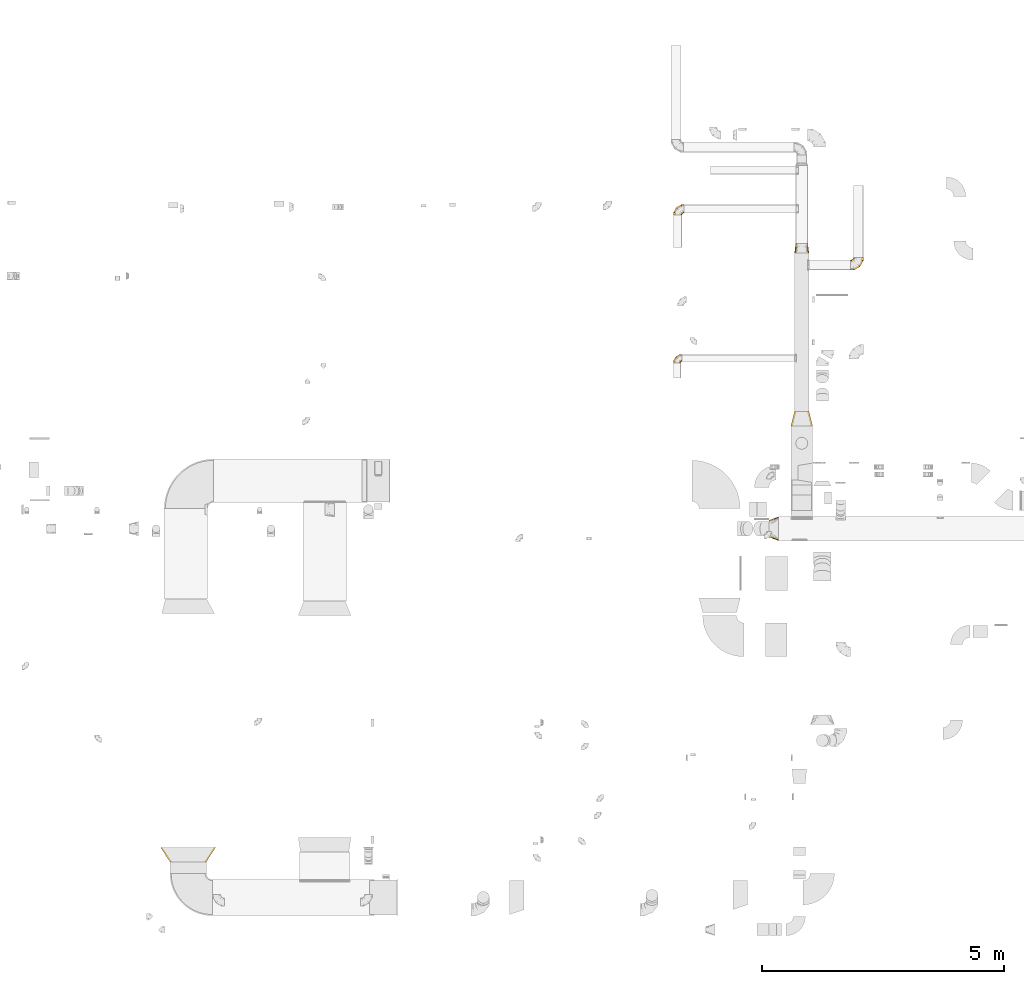
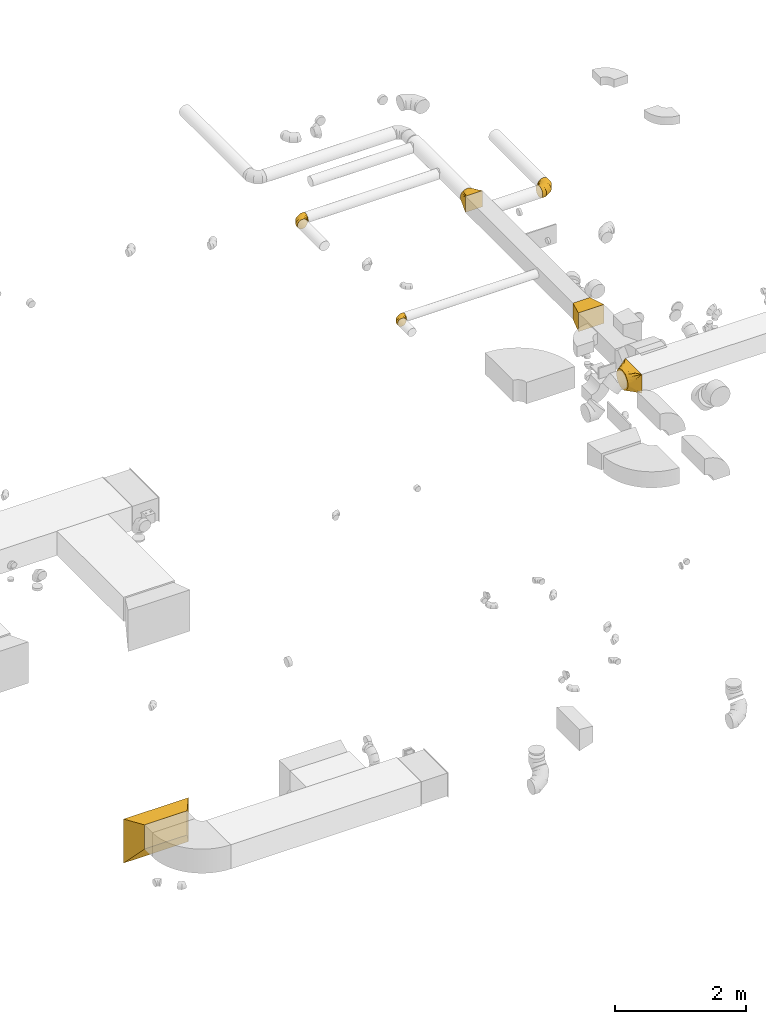
# One storey, part 6 of 62: 7 coverings.
"""IFC2X3 building model written with IfcOpenShell, lengths in millimetres."""

from ifc_helpers import new_model, entity, si_unit, converted_unit, derived_unit, direction, frame, origin, place, context, subcontext, project, spatial, faceted_brep, element, save


model = new_model("IFC2X3")

# Units and contexts
model_context = context("Model", 3, precision=0.01, world=origin(), true_north=direction((6.12303176911189e-17, 1.0)))
body_context = subcontext(model_context, "Body", "Model", "MODEL_VIEW")
ifc_project = project(units=[si_unit("LENGTHUNIT", "METRE", prefix="MILLI"), si_unit("AREAUNIT", "SQUARE_METRE"), si_unit("VOLUMEUNIT", "CUBIC_METRE"), converted_unit("PLANEANGLEUNIT", "DEGREE", entity("IfcRatioMeasure", 0.0174532925199433), si_unit("PLANEANGLEUNIT", "RADIAN"), dimensions=[0, 0, 0, 0, 0, 0, 0]), si_unit("MASSUNIT", "GRAM", prefix="KILO"), derived_unit("MASSDENSITYUNIT", [(si_unit("MASSUNIT", "GRAM", prefix="KILO"), 1), (si_unit("LENGTHUNIT", "METRE"), -3)]), derived_unit("MOMENTOFINERTIAUNIT", [(si_unit("LENGTHUNIT", "METRE"), 4)]), si_unit("TIMEUNIT", "SECOND"), si_unit("FREQUENCYUNIT", "HERTZ"), si_unit("THERMODYNAMICTEMPERATUREUNIT", "DEGREE_CELSIUS"), derived_unit("THERMALTRANSMITTANCEUNIT", [(si_unit("MASSUNIT", "GRAM", prefix="KILO"), 1), (si_unit("THERMODYNAMICTEMPERATUREUNIT", "KELVIN"), -1), (si_unit("TIMEUNIT", "SECOND"), -3)]), derived_unit("VOLUMETRICFLOWRATEUNIT", [(si_unit("LENGTHUNIT", "METRE"), 3), (si_unit("TIMEUNIT", "SECOND"), -1)]), derived_unit("MASSFLOWRATEUNIT", [(si_unit("MASSUNIT", "GRAM", prefix="KILO"), 1), (si_unit("TIMEUNIT", "SECOND"), -1)]), derived_unit("ROTATIONALFREQUENCYUNIT", [(si_unit("TIMEUNIT", "SECOND"), -1)]), si_unit("ELECTRICCURRENTUNIT", "AMPERE"), si_unit("ELECTRICVOLTAGEUNIT", "VOLT"), si_unit("POWERUNIT", "WATT"), si_unit("FORCEUNIT", "NEWTON", prefix="KILO"), si_unit("ILLUMINANCEUNIT", "LUX"), si_unit("LUMINOUSFLUXUNIT", "LUMEN"), si_unit("LUMINOUSINTENSITYUNIT", "CANDELA"), derived_unit("USERDEFINED", [(si_unit("MASSUNIT", "GRAM", prefix="KILO"), -1), (si_unit("LENGTHUNIT", "METRE"), -2), (si_unit("TIMEUNIT", "SECOND"), 3), (si_unit("LUMINOUSFLUXUNIT", "LUMEN"), 1)]), derived_unit("LINEARVELOCITYUNIT", [(si_unit("LENGTHUNIT", "METRE"), 1), (si_unit("TIMEUNIT", "SECOND"), -1)]), si_unit("PRESSUREUNIT", "PASCAL"), derived_unit("USERDEFINED", [(si_unit("LENGTHUNIT", "METRE"), -2), (si_unit("MASSUNIT", "GRAM", prefix="KILO"), 1), (si_unit("TIMEUNIT", "SECOND"), -2)]), derived_unit("LINEARFORCEUNIT", [(si_unit("MASSUNIT", "GRAM", prefix="KILO"), 1), (si_unit("LENGTHUNIT", "METRE"), 1), (si_unit("TIMEUNIT", "SECOND"), -2), (si_unit("LENGTHUNIT", "METRE"), -1)]), derived_unit("PLANARFORCEUNIT", [(si_unit("MASSUNIT", "GRAM", prefix="KILO"), 1), (si_unit("LENGTHUNIT", "METRE"), 1), (si_unit("TIMEUNIT", "SECOND"), -2), (si_unit("LENGTHUNIT", "METRE"), -2)])], contexts=[model_context])

# Site, building, storey
site_placement = place(None, origin())
site = spatial("IfcSite", under=ifc_project, at=site_placement, CompositionType="ELEMENT")
building_placement = place(site_placement, origin())
building = spatial("IfcBuilding", under=site, at=building_placement, CompositionType="ELEMENT")
storey_placement = place(building_placement, frame((0.0, 0.0, 24000.0)))
storey = spatial("IfcBuildingStorey", under=building, at=storey_placement, CompositionType="ELEMENT", Elevation=24000.0)

# Coverings
covering_1_placement = place(storey_placement, frame((39417.06, 8674.98, 3373.4)))
element("IfcCovering", 1, at=covering_1_placement, inside=storey, PredefinedType="INSULATION", context=body_context, shape_type="Brep", body=[
    faceted_brep([(0.0, 98.45, 264.1), (0.0, 112.35, 282.22), (0.0, 126.26, 300.34), (0.0, 144.38, 314.24), (0.0, 162.5, 328.15), (0.0, 183.6, 336.89), (0.0, 204.71, 345.63), (0.0, 218.97, 347.51), (0.0, 233.22, 349.39), (0.0, 250.0, 351.6), (0.0, 266.78, 349.39), (0.0, 281.03, 347.51), (0.0, 295.29, 345.63), (0.0, 316.4, 336.89), (0.0, 337.5, 328.15), (0.0, 355.62, 314.24), (0.0, 373.74, 300.34), (0.0, 387.65, 282.22), (0.0, 401.55, 264.1), (0.0, 410.3, 242.99), (0.0, 419.04, 221.89), (0.0, 420.91, 207.63), (0.0, 422.79, 193.37), (0.0, 425.0, 176.6), (0.0, 422.79, 159.82), (0.0, 420.91, 145.56), (0.0, 419.04, 131.3), (0.0, 410.3, 110.2), (0.0, 401.55, 89.1), (0.0, 387.65, 70.97), (0.0, 373.74, 52.85), (0.0, 355.62, 38.95), (0.0, 337.5, 25.04), (0.0, 316.4, 16.3), (0.0, 295.29, 7.56), (0.0, 281.03, 5.68), (0.0, 266.78, 3.8), (0.0, 250.0, 1.6), (0.0, 233.22, 3.8), (0.0, 218.97, 5.68), (0.0, 204.71, 7.56), (0.0, 183.6, 16.3), (0.0, 162.5, 25.04), (0.0, 144.38, 38.95), (0.0, 126.26, 52.85), (0.0, 112.35, 70.97), (0.0, 98.45, 89.1), (0.0, 89.7, 110.2), (0.0, 80.96, 131.3), (0.0, 79.09, 145.56), (0.0, 77.21, 159.82), (0.0, 75.0, 176.6), (0.0, 77.21, 193.37), (0.0, 79.09, 207.63), (0.0, 80.96, 221.89), (0.0, 89.7, 242.99), (200.0, 0.0, 351.6), (200.0, 0.0, 1.6), (200.0, 500.0, 1.6), (200.0, 500.0, 351.6), (71.91, 160.11, 1.6), (95.89, 130.14, 1.6), (121.91, 97.61, 1.6), (100.0, 66.99, 23.59), (173.97, 32.54, 1.6), (147.94, 19.52, 47.15), (173.97, 9.76, 24.37), (121.91, 29.28, 69.92), (95.89, 39.04, 92.7), (71.91, 48.03, 113.67), (23.97, 220.04, 1.6), (47.94, 190.07, 1.6), (47.94, 57.02, 134.65), (23.97, 66.01, 155.62), (147.94, 65.07, 1.6), (173.97, 9.76, 328.82), (147.94, 19.52, 306.05), (121.91, 29.28, 283.27), (95.89, 39.04, 260.5), (71.91, 48.03, 239.52), (47.94, 57.02, 218.55), (23.97, 66.01, 197.57), (100.0, 59.5, 322.11), (147.94, 65.07, 351.6), (173.97, 32.54, 351.6), (121.91, 97.61, 351.6), (95.89, 130.14, 351.6), (71.91, 160.11, 351.6), (47.94, 190.07, 351.6), (23.97, 220.04, 351.6), (173.97, 467.46, 351.6), (147.94, 434.93, 351.6), (121.91, 402.39, 351.6), (95.89, 369.86, 351.6), (71.91, 339.89, 351.6), (47.94, 309.93, 351.6), (23.97, 279.96, 351.6), (100.0, 433.01, 329.6), (147.94, 480.48, 306.05), (173.97, 490.24, 328.82), (121.91, 470.72, 283.27), (95.89, 460.96, 260.5), (71.91, 451.97, 239.52), (47.94, 442.98, 218.55), (23.97, 433.99, 197.57), (173.97, 490.24, 24.37), (147.94, 480.48, 47.15), (121.91, 470.72, 69.92), (95.89, 460.96, 92.7), (71.91, 451.97, 113.67), (47.94, 442.98, 134.65), (23.97, 433.99, 155.62), (100.0, 440.5, 31.08), (147.94, 434.93, 1.6), (173.97, 467.46, 1.6), (121.91, 402.39, 1.6), (95.89, 369.86, 1.6), (71.91, 339.89, 1.6), (47.94, 309.93, 1.6), (23.97, 279.96, 1.6)], [[[0, 1, 2, 3, 4, 5, 6, 7, 8, 9, 10, 11, 12, 13, 14, 15, 16, 17, 18, 19, 20, 21, 22, 23, 24, 25, 26, 27, 28, 29, 30, 31, 32, 33, 34, 35, 36, 37, 38, 39, 40, 41, 42, 43, 44, 45, 46, 47, 48, 49, 50, 51, 52, 53, 54, 55]], [[56, 57, 58, 59]], [[60, 61, 62, 41]], [[63, 43, 64]], [[45, 44, 63]], [[40, 60, 41]], [[41, 62, 42]], [[65, 46, 45]], [[45, 63, 66]], [[47, 67, 68, 69]], [[70, 71, 60, 40, 39, 38, 37]], [[49, 48, 69, 72, 73, 51, 50]], [[47, 46, 67]], [[47, 69, 48]], [[46, 65, 67]], [[43, 74, 64]], [[43, 42, 74]], [[57, 63, 64]], [[43, 63, 44]], [[45, 66, 65]], [[63, 57, 66]], [[62, 74, 42]], [[57, 56, 75, 76, 77, 78, 79, 80, 81, 51, 73, 72, 69, 68, 67, 65, 66]], [[79, 78, 77, 55]], [[82, 1, 75]], [[3, 2, 82]], [[54, 79, 55]], [[55, 77, 0]], [[83, 4, 3]], [[3, 82, 84]], [[5, 85, 86, 87]], [[81, 80, 79, 54, 53, 52, 51]], [[7, 6, 87, 88, 89, 9, 8]], [[5, 4, 85]], [[5, 87, 6]], [[4, 83, 85]], [[1, 76, 75]], [[1, 0, 76]], [[56, 82, 75]], [[1, 82, 2]], [[3, 84, 83]], [[82, 56, 84]], [[77, 76, 0]], [[56, 59, 90, 91, 92, 93, 94, 95, 96, 9, 89, 88, 87, 86, 85, 83, 84]], [[94, 93, 92, 13]], [[97, 15, 90]], [[17, 16, 97]], [[12, 94, 13]], [[13, 92, 14]], [[98, 18, 17]], [[17, 97, 99]], [[19, 100, 101, 102]], [[96, 95, 94, 12, 11, 10, 9]], [[21, 20, 102, 103, 104, 23, 22]], [[19, 18, 100]], [[19, 102, 20]], [[18, 98, 100]], [[15, 91, 90]], [[15, 14, 91]], [[59, 97, 90]], [[15, 97, 16]], [[17, 99, 98]], [[97, 59, 99]], [[92, 91, 14]], [[59, 58, 105, 106, 107, 108, 109, 110, 111, 23, 104, 103, 102, 101, 100, 98, 99]], [[109, 108, 107, 27]], [[112, 29, 105]], [[31, 30, 112]], [[26, 109, 27]], [[27, 107, 28]], [[113, 32, 31]], [[31, 112, 114]], [[33, 115, 116, 117]], [[111, 110, 109, 26, 25, 24, 23]], [[35, 34, 117, 118, 119, 37, 36]], [[33, 32, 115]], [[33, 117, 34]], [[32, 113, 115]], [[29, 106, 105]], [[29, 28, 106]], [[58, 112, 105]], [[29, 112, 30]], [[31, 114, 113]], [[112, 58, 114]], [[107, 106, 28]], [[119, 118, 117, 116, 115, 113, 114, 58, 57, 64, 74, 62, 61, 60, 71, 70, 37]]]),
])
covering_2_placement = place(storey_placement, frame((39870.11, 11046.34, 2995.0)))
element("IfcCovering", 2, at=covering_2_placement, inside=storey, PredefinedType="INSULATION", context=body_context, shape_type="Brep", body=[
    faceted_brep([(0.0, 0.0, 350.0), (0.0, 0.0, 0.0), (450.0, 0.0, 0.0), (450.0, 0.0, 350.0), (75.0, 300.0, 325.0), (375.0, 300.0, 325.0), (375.0, 300.0, 25.0), (75.0, 300.0, 25.0)], [[[0, 1, 2, 3]], [[4, 5, 6, 7]], [[4, 7, 1, 0]], [[7, 6, 2, 1]], [[6, 5, 3, 2]], [[5, 4, 0, 3]]]),
])
covering_3_placement = place(storey_placement, frame((37440.61, 12355.11, 3123.4)))
element("IfcCovering", 3, at=covering_3_placement, inside=storey, PredefinedType="INSULATION", context=body_context, shape_type="Brep", body=[
    faceted_brep([(35.73, 0.0, 137.76), (23.56, 0.0, 129.63), (15.43, 0.0, 117.46), (7.3, 0.0, 105.3), (4.45, 0.0, 90.95), (1.6, 0.0, 76.6), (4.45, 0.0, 62.24), (7.3, 0.0, 47.89), (15.43, 0.0, 35.73), (23.56, 0.0, 23.56), (35.73, 0.0, 15.43), (47.89, 0.0, 7.3), (62.24, 0.0, 4.45), (76.6, 0.0, 1.6), (90.95, 0.0, 4.45), (105.3, 0.0, 7.3), (117.46, 0.0, 15.43), (129.63, 0.0, 23.56), (137.76, 0.0, 35.73), (145.89, 0.0, 47.89), (148.74, 0.0, 62.24), (150.17, 0.0, 69.42), (151.6, 0.0, 76.6), (150.17, 0.0, 83.77), (148.74, 0.0, 90.95), (145.89, 0.0, 105.3), (137.76, 0.0, 117.46), (129.63, 0.0, 129.63), (117.46, 0.0, 137.76), (105.3, 0.0, 145.89), (90.95, 0.0, 148.74), (76.6, 0.0, 151.6), (62.24, 0.0, 148.74), (47.89, 0.0, 145.89), (176.6, 172.44, 57.18), (176.6, 175.0, 76.6), (176.6, 172.44, 96.01), (176.6, 164.95, 114.1), (176.6, 153.03, 129.63), (176.6, 137.5, 141.55), (176.6, 119.41, 149.04), (176.6, 100.0, 151.6), (176.6, 80.59, 149.04), (176.6, 62.5, 141.55), (176.6, 46.97, 129.63), (176.6, 35.05, 114.1), (176.6, 27.56, 96.01), (176.6, 25.0, 76.6), (176.6, 27.56, 57.18), (176.6, 35.05, 39.1), (176.6, 46.97, 23.56), (176.6, 62.5, 11.64), (176.6, 80.59, 4.15), (176.6, 100.0, 1.6), (176.6, 119.41, 4.15), (176.6, 137.5, 11.64), (176.6, 153.03, 23.56), (176.6, 164.95, 39.1), (129.7, 175.0, 76.6), (130.39, 172.44, 96.01), (132.4, 164.95, 114.1), (135.59, 153.03, 129.63), (139.75, 137.5, 141.55), (144.6, 119.41, 149.04), (149.8, 100.0, 151.6), (155.0, 80.59, 149.04), (159.85, 62.5, 141.55), (164.01, 46.97, 129.63), (167.2, 35.05, 114.1), (169.21, 27.56, 96.01), (169.9, 25.0, 76.6), (169.21, 27.56, 57.18), (167.2, 35.05, 39.1), (164.01, 46.97, 23.56), (155.0, 80.59, 4.15), (149.8, 100.0, 1.6), (159.85, 62.5, 11.64), (144.6, 119.41, 4.15), (139.75, 137.5, 11.64), (135.59, 153.03, 23.56), (132.4, 164.95, 39.1), (130.39, 172.44, 57.18), (48.49, 128.11, 76.6), (50.36, 126.24, 96.01), (55.84, 120.75, 114.1), (64.57, 112.03, 129.63), (75.94, 100.66, 141.55), (89.18, 87.42, 149.04), (103.39, 73.21, 151.6), (117.6, 58.99, 149.04), (130.84, 45.75, 141.55), (142.21, 34.38, 129.63), (150.94, 25.66, 114.1), (156.42, 20.17, 96.01), (158.29, 18.3, 76.6), (156.42, 20.17, 57.18), (150.94, 25.66, 39.1), (142.21, 34.38, 23.56), (117.6, 58.99, 4.15), (103.39, 73.21, 1.6), (130.84, 45.75, 11.64), (89.18, 87.42, 4.15), (75.94, 100.66, 11.64), (64.57, 112.03, 23.56), (55.84, 120.75, 39.1), (50.36, 126.24, 57.18), (1.6, 46.89, 76.6), (4.15, 46.21, 96.01), (11.64, 44.2, 114.1), (23.56, 41.01, 129.63), (39.1, 36.84, 141.55), (57.18, 32.0, 149.04), (76.6, 26.79, 151.6), (96.01, 21.59, 149.04), (114.1, 16.75, 141.55), (129.63, 12.58, 129.63), (141.55, 9.39, 114.1), (145.29, 8.39, 105.05), (149.04, 7.38, 96.01), (150.32, 7.04, 86.3), (151.6, 6.7, 76.6), (149.04, 7.38, 57.18), (145.29, 8.39, 48.14), (141.55, 9.39, 39.1), (150.32, 7.04, 66.89), (129.63, 12.58, 23.56), (96.01, 21.59, 4.15), (76.6, 26.79, 1.6), (114.1, 16.75, 11.64), (57.18, 32.0, 4.15), (39.1, 36.84, 11.64), (23.56, 41.01, 23.56), (11.64, 44.2, 39.1), (4.15, 46.21, 57.18)], [[[0, 1, 2, 3, 4, 5, 6, 7, 8, 9, 10, 11, 12, 13, 14, 15, 16, 17, 18, 19, 20, 21, 22, 23, 24, 25, 26, 27, 28, 29, 30, 31, 32, 33]], [[34, 35, 36, 37, 38, 39, 40, 41, 42, 43, 44, 45, 46, 47, 48, 49, 50, 51, 52, 53, 54, 55, 56, 57]], [[35, 58, 59, 36]], [[36, 59, 60, 37]], [[37, 60, 61, 38]], [[39, 62, 63, 40]], [[40, 63, 64, 41]], [[38, 61, 62, 39]], [[65, 66, 43, 42]], [[64, 65, 42, 41]], [[67, 44, 43, 66]], [[68, 69, 46, 45]], [[68, 45, 44, 67]], [[70, 47, 46, 69]], [[71, 72, 49, 48]], [[70, 71, 48, 47]], [[50, 49, 72, 73]], [[74, 75, 53, 52]], [[76, 74, 52, 51]], [[73, 76, 51, 50]], [[55, 54, 77, 78]], [[56, 55, 78, 79]], [[53, 75, 77, 54]], [[34, 57, 80, 81]], [[35, 34, 81, 58]], [[79, 80, 57, 56]], [[58, 82, 83, 59]], [[60, 59, 83, 84]], [[84, 85, 61, 60]], [[62, 61, 85, 86]], [[63, 62, 86, 87]], [[64, 63, 87, 88]], [[89, 90, 66, 65]], [[88, 89, 65, 64]], [[67, 66, 90, 91]], [[92, 93, 69, 68]], [[91, 92, 68, 67]], [[70, 69, 93, 94]], [[95, 96, 72, 71]], [[94, 95, 71, 70]], [[73, 72, 96, 97]], [[98, 99, 75, 74]], [[100, 98, 74, 76]], [[97, 100, 76, 73]], [[77, 75, 99, 101]], [[78, 77, 101, 102]], [[79, 78, 102, 103]], [[81, 80, 104, 105]], [[58, 81, 105, 82]], [[103, 104, 80, 79]], [[82, 106, 107, 83]], [[84, 83, 107, 108]], [[108, 109, 85, 84]], [[86, 85, 109, 110]], [[87, 86, 110, 111]], [[88, 87, 111, 112]], [[113, 114, 90, 89]], [[112, 113, 89, 88]], [[91, 90, 114, 115]], [[93, 92, 116, 117, 118]], [[115, 116, 92, 91]], [[94, 93, 118, 119, 120]], [[95, 121, 122, 123, 96]], [[94, 120, 124, 121, 95]], [[97, 96, 123, 125]], [[126, 127, 99, 98]], [[128, 126, 98, 100]], [[125, 128, 100, 97]], [[101, 99, 127, 129]], [[102, 101, 129, 130]], [[103, 102, 130, 131]], [[105, 104, 132, 133]], [[82, 105, 133, 106]], [[131, 132, 104, 103]], [[106, 4, 107]], [[111, 33, 32]], [[4, 106, 5]], [[1, 109, 2]], [[108, 3, 2]], [[107, 3, 108]], [[0, 33, 110]], [[108, 2, 109]], [[0, 109, 1]], [[31, 112, 32]], [[4, 3, 107]], [[112, 111, 32]], [[110, 33, 111]], [[109, 0, 110]], [[113, 31, 30, 29]], [[27, 115, 28]], [[119, 24, 23]], [[114, 29, 28]], [[114, 113, 29]], [[120, 23, 22]], [[114, 28, 115]], [[31, 113, 112]], [[120, 119, 23]], [[24, 119, 118]], [[25, 118, 117, 116]], [[27, 26, 115]], [[115, 26, 116]], [[118, 25, 24]], [[116, 26, 25]], [[121, 20, 19]], [[18, 17, 125]], [[19, 123, 122, 121]], [[21, 20, 124]], [[21, 120, 22]], [[125, 123, 18]], [[16, 125, 17]], [[126, 15, 14, 13]], [[125, 16, 128]], [[120, 21, 124]], [[126, 128, 15]], [[126, 13, 127]], [[20, 121, 124]], [[123, 19, 18]], [[16, 15, 128]], [[127, 12, 129]], [[9, 131, 10]], [[130, 11, 10]], [[129, 11, 130]], [[8, 131, 9]], [[12, 11, 129]], [[130, 10, 131]], [[12, 127, 13]], [[133, 7, 6]], [[131, 8, 132]], [[5, 106, 6]], [[7, 133, 132]], [[106, 133, 6]], [[8, 7, 132]]]),
])
covering_4_placement = place(storey_placement, frame((41105.96, 14274.27, 3043.4)))
element("IfcCovering", 4, at=covering_4_placement, inside=storey, PredefinedType="INSULATION", context=body_context, shape_type="Brep", body=[
    faceted_brep([(160.0, 266.6, 211.6), (192.45, 266.6, 206.46), (221.72, 266.6, 191.54), (244.95, 266.6, 168.31), (259.86, 266.6, 139.04), (265.0, 266.6, 106.6), (259.86, 266.6, 74.15), (244.95, 266.6, 44.88), (221.72, 266.6, 21.65), (192.45, 266.6, 6.73), (160.0, 266.6, 1.6), (127.55, 266.6, 6.73), (98.28, 266.6, 21.65), (75.05, 266.6, 44.88), (60.14, 266.6, 74.15), (55.0, 266.6, 106.6), (60.14, 266.6, 139.04), (75.05, 266.6, 168.31), (98.28, 266.6, 191.54), (127.55, 266.6, 206.46), (0.0, 15.66, 54.1), (0.0, 5.17, 79.42), (0.0, 1.6, 106.6), (0.0, 5.17, 133.77), (0.0, 15.66, 159.1), (0.0, 32.35, 180.84), (0.0, 54.1, 197.53), (0.0, 79.42, 208.02), (0.0, 106.6, 211.6), (0.0, 133.77, 208.02), (0.0, 159.1, 197.53), (0.0, 180.84, 180.84), (0.0, 197.53, 159.1), (0.0, 208.02, 133.77), (0.0, 211.6, 106.6), (0.0, 208.02, 79.42), (0.0, 197.53, 54.1), (0.0, 180.84, 32.35), (0.0, 159.1, 15.66), (0.0, 133.77, 5.17), (0.0, 106.6, 1.6), (0.0, 79.42, 5.17), (0.0, 54.1, 15.66), (0.0, 32.35, 32.35), (71.01, 1.6, 106.6), (70.05, 5.17, 133.77), (67.24, 15.66, 159.1), (62.77, 32.35, 180.84), (56.94, 54.1, 197.53), (50.15, 79.42, 208.02), (42.87, 106.6, 211.6), (35.59, 133.77, 208.02), (28.8, 159.1, 197.53), (22.98, 180.84, 180.84), (18.51, 197.53, 159.1), (15.7, 208.02, 133.77), (14.74, 211.6, 106.6), (15.7, 208.02, 79.42), (18.51, 197.53, 54.1), (22.98, 180.84, 32.35), (35.59, 133.77, 5.17), (42.87, 106.6, 1.6), (28.8, 159.1, 15.66), (50.15, 79.42, 5.17), (56.94, 54.1, 15.66), (62.77, 32.35, 32.35), (67.24, 15.66, 54.1), (70.05, 5.17, 79.42), (193.99, 72.6, 106.6), (191.37, 75.22, 133.77), (183.7, 82.9, 159.1), (171.48, 95.12, 180.84), (155.56, 111.03, 197.53), (137.02, 129.57, 208.02), (117.13, 149.47, 211.6), (97.23, 169.36, 208.02), (78.7, 187.9, 197.53), (62.78, 203.82, 180.84), (50.56, 216.03, 159.1), (42.88, 223.71, 133.77), (40.26, 226.33, 106.6), (42.88, 223.71, 79.42), (50.56, 216.03, 54.1), (62.78, 203.82, 32.35), (97.23, 169.36, 5.17), (117.13, 149.47, 1.6), (78.7, 187.9, 15.66), (137.02, 129.57, 5.17), (155.56, 111.03, 15.66), (171.48, 95.12, 32.35), (183.7, 82.9, 54.1), (191.37, 75.22, 79.42), (265.0, 195.59, 106.6), (261.42, 196.55, 133.77), (250.93, 199.36, 159.1), (234.25, 203.83, 180.84), (212.5, 209.66, 197.53), (187.18, 216.44, 208.02), (160.0, 223.72, 211.6), (132.82, 231.01, 208.02), (107.5, 237.79, 197.53), (85.75, 243.62, 180.84), (69.07, 248.09, 159.1), (58.58, 250.9, 133.77), (55.0, 251.86, 106.6), (58.58, 250.9, 79.42), (69.07, 248.09, 54.1), (85.75, 243.62, 32.35), (132.82, 231.01, 5.17), (160.0, 223.72, 1.6), (107.5, 237.79, 15.66), (187.18, 216.44, 5.17), (212.5, 209.66, 15.66), (234.25, 203.83, 32.35), (250.93, 199.36, 54.1), (261.42, 196.55, 79.42)], [[[0, 1, 2, 3, 4, 5, 6, 7, 8, 9, 10, 11, 12, 13, 14, 15, 16, 17, 18, 19]], [[20, 21, 22, 23, 24, 25, 26, 27, 28, 29, 30, 31, 32, 33, 34, 35, 36, 37, 38, 39, 40, 41, 42, 43]], [[22, 44, 45, 23]], [[23, 45, 46, 24]], [[24, 46, 47, 25]], [[25, 47, 48, 26]], [[26, 48, 49, 27]], [[50, 28, 27, 49]], [[51, 52, 30, 29]], [[50, 51, 29, 28]], [[53, 31, 30, 52]], [[54, 55, 33, 32]], [[54, 32, 31, 53]], [[56, 34, 33, 55]], [[57, 58, 36, 35]], [[56, 57, 35, 34]], [[37, 36, 58, 59]], [[60, 61, 40, 39]], [[62, 60, 39, 38]], [[59, 62, 38, 37]], [[41, 40, 61, 63]], [[42, 41, 63, 64]], [[64, 65, 43, 42]], [[21, 20, 66, 67]], [[22, 21, 67, 44]], [[65, 66, 20, 43]], [[45, 44, 68, 69]], [[46, 45, 69, 70]], [[70, 71, 47, 46]], [[48, 47, 71, 72]], [[49, 48, 72, 73]], [[50, 49, 73, 74]], [[75, 76, 52, 51]], [[74, 75, 51, 50]], [[53, 52, 76, 77]], [[78, 79, 55, 54]], [[77, 78, 54, 53]], [[56, 55, 79, 80]], [[81, 82, 58, 57]], [[80, 81, 57, 56]], [[59, 58, 82, 83]], [[84, 85, 61, 60]], [[86, 84, 60, 62]], [[83, 86, 62, 59]], [[63, 61, 85, 87]], [[64, 63, 87, 88]], [[65, 64, 88, 89]], [[67, 66, 90, 91]], [[44, 67, 91, 68]], [[89, 90, 66, 65]], [[69, 68, 92, 93]], [[70, 69, 93, 94]], [[94, 95, 71, 70]], [[72, 71, 95, 96]], [[73, 72, 96, 97]], [[74, 73, 97, 98]], [[99, 100, 76, 75]], [[98, 99, 75, 74]], [[77, 76, 100, 101]], [[102, 103, 79, 78]], [[101, 102, 78, 77]], [[80, 79, 103, 104]], [[105, 106, 82, 81]], [[104, 105, 81, 80]], [[83, 82, 106, 107]], [[108, 109, 85, 84]], [[110, 108, 84, 86]], [[107, 110, 86, 83]], [[87, 85, 109, 111]], [[88, 87, 111, 112]], [[89, 88, 112, 113]], [[91, 90, 114, 115]], [[68, 91, 115, 92]], [[113, 114, 90, 89]], [[93, 5, 4]], [[94, 4, 3]], [[5, 93, 92]], [[93, 4, 94]], [[3, 95, 94]], [[96, 2, 1]], [[97, 1, 0]], [[95, 2, 96]], [[96, 1, 97]], [[0, 98, 97]], [[2, 95, 3]], [[99, 0, 19]], [[100, 19, 18]], [[99, 98, 0]], [[100, 99, 19]], [[18, 101, 100]], [[102, 17, 16]], [[103, 16, 15]], [[102, 101, 17]], [[104, 103, 15]], [[102, 16, 103]], [[17, 101, 18]], [[105, 15, 14]], [[106, 14, 13]], [[105, 104, 15]], [[106, 105, 14]], [[13, 107, 106]], [[110, 12, 11]], [[108, 11, 10]], [[110, 107, 12]], [[109, 108, 10]], [[110, 11, 108]], [[12, 107, 13]], [[9, 8, 112]], [[10, 9, 111]], [[10, 111, 109]], [[111, 9, 112]], [[8, 113, 112]], [[114, 7, 6]], [[115, 6, 5]], [[113, 7, 114]], [[115, 114, 6]], [[92, 115, 5]], [[7, 113, 8]]]),
])
covering_5_placement = place(storey_placement, frame((39945.11, 14626.34, 3020.0)))
element("IfcCovering", 5, at=covering_5_placement, inside=storey, PredefinedType="INSULATION", context=body_context, shape_type="Brep", body=[
    faceted_brep([(150.0, 200.0, 275.0), (155.96, 200.0, 274.06), (161.92, 200.0, 273.11), (173.84, 200.0, 271.22), (188.63, 200.0, 268.88), (206.05, 200.0, 260.0), (223.47, 200.0, 251.13), (237.3, 200.0, 237.3), (251.13, 200.0, 223.47), (260.0, 200.0, 206.05), (268.88, 200.0, 188.63), (271.22, 200.0, 173.84), (273.11, 200.0, 161.92), (274.06, 200.0, 155.96), (275.0, 200.0, 150.0), (274.06, 200.0, 144.04), (273.11, 200.0, 138.08), (271.22, 200.0, 126.16), (268.88, 200.0, 111.37), (260.0, 200.0, 93.95), (251.13, 200.0, 76.53), (237.3, 200.0, 62.7), (223.47, 200.0, 48.87), (206.05, 200.0, 40.0), (188.63, 200.0, 31.12), (173.84, 200.0, 28.78), (161.92, 200.0, 26.89), (155.96, 200.0, 25.94), (150.0, 200.0, 25.0), (144.04, 200.0, 25.94), (138.08, 200.0, 26.89), (126.16, 200.0, 28.78), (111.37, 200.0, 31.12), (93.95, 200.0, 40.0), (76.53, 200.0, 48.87), (62.7, 200.0, 62.7), (48.87, 200.0, 76.53), (40.0, 200.0, 93.95), (31.12, 200.0, 111.37), (28.78, 200.0, 126.16), (26.89, 200.0, 138.08), (25.94, 200.0, 144.04), (25.0, 200.0, 150.0), (25.94, 200.0, 155.96), (26.89, 200.0, 161.92), (28.78, 200.0, 173.84), (31.12, 200.0, 188.63), (40.0, 200.0, 206.05), (48.87, 200.0, 223.47), (62.7, 200.0, 237.3), (76.53, 200.0, 251.13), (93.95, 200.0, 260.0), (111.37, 200.0, 268.88), (126.16, 200.0, 271.22), (138.08, 200.0, 273.11), (144.04, 200.0, 274.06), (0.0, 0.0, 300.0), (0.0, 0.0, 0.0), (300.0, 0.0, 0.0), (300.0, 0.0, 300.0), (78.09, 104.11, 13.01), (33.56, 100.0, 28.21), (19.52, 26.03, 3.25), (58.56, 78.09, 9.76), (39.04, 52.06, 6.51), (141.01, 188.01, 23.5), (132.02, 176.03, 22.0), (114.04, 152.06, 19.01), (96.06, 128.09, 16.01), (6.51, 52.06, 39.04), (9.76, 78.09, 58.56), (13.01, 104.11, 78.09), (16.01, 128.09, 96.06), (19.01, 152.06, 114.04), (22.0, 176.03, 132.02), (23.5, 188.01, 141.01), (3.25, 26.03, 19.52), (3.25, 26.03, 280.48), (6.51, 52.06, 260.96), (9.76, 78.09, 241.44), (13.01, 104.11, 221.91), (16.01, 128.09, 203.94), (19.01, 152.06, 185.96), (22.0, 176.03, 167.98), (23.5, 188.01, 158.99), (28.21, 100.0, 266.44), (39.04, 52.06, 293.49), (58.56, 78.09, 290.24), (78.09, 104.11, 286.99), (96.06, 128.09, 283.99), (114.04, 152.06, 280.99), (132.02, 176.03, 278.0), (141.01, 188.01, 276.5), (19.52, 26.03, 296.75), (280.48, 26.03, 296.75), (260.96, 52.06, 293.49), (241.44, 78.09, 290.24), (221.91, 104.11, 286.99), (203.94, 128.09, 283.99), (185.96, 152.06, 280.99), (167.98, 176.03, 278.0), (158.99, 188.01, 276.5), (266.44, 100.0, 271.79), (293.49, 52.06, 260.96), (290.24, 78.09, 241.44), (286.99, 104.11, 221.91), (283.99, 128.09, 203.94), (280.99, 152.06, 185.96), (278.0, 176.03, 167.98), (276.5, 188.01, 158.99), (296.75, 26.03, 280.48), (296.75, 26.03, 19.52), (293.49, 52.06, 39.04), (290.24, 78.09, 58.56), (286.99, 104.11, 78.09), (283.99, 128.09, 96.06), (280.99, 152.06, 114.04), (278.0, 176.03, 132.02), (276.5, 188.01, 141.01), (271.79, 100.0, 33.56), (260.96, 52.06, 6.51), (241.44, 78.09, 9.76), (221.91, 104.11, 13.01), (203.94, 128.09, 16.01), (185.96, 152.06, 19.01), (167.98, 176.03, 22.0), (158.99, 188.01, 23.5), (280.48, 26.03, 3.25)], [[[0, 1, 2, 3, 4, 5, 6, 7, 8, 9, 10, 11, 12, 13, 14, 15, 16, 17, 18, 19, 20, 21, 22, 23, 24, 25, 26, 27, 28, 29, 30, 31, 32, 33, 34, 35, 36, 37, 38, 39, 40, 41, 42, 43, 44, 45, 46, 47, 48, 49, 50, 51, 52, 53, 54, 55]], [[56, 57, 58, 59]], [[60, 33, 32]], [[57, 61, 62]], [[33, 60, 63, 64]], [[65, 66, 67, 68, 60, 32, 31, 30, 29, 28]], [[62, 61, 34]], [[37, 69, 70, 71]], [[64, 34, 33]], [[38, 71, 72, 73, 74, 75, 42, 41, 40, 39]], [[36, 76, 69]], [[71, 38, 37]], [[61, 76, 35]], [[34, 64, 62]], [[76, 36, 35]], [[34, 61, 35]], [[61, 57, 76]], [[69, 37, 36]], [[57, 56, 77, 78, 79, 80, 81, 82, 83, 84, 42, 75, 74, 73, 72, 71, 70, 69, 76]], [[80, 47, 46]], [[56, 85, 77]], [[47, 80, 79, 78]], [[84, 83, 82, 81, 80, 46, 45, 44, 43, 42]], [[77, 85, 48]], [[51, 86, 87, 88]], [[78, 48, 47]], [[52, 88, 89, 90, 91, 92, 0, 55, 54, 53]], [[50, 93, 86]], [[88, 52, 51]], [[85, 93, 49]], [[48, 78, 77]], [[93, 50, 49]], [[48, 85, 49]], [[85, 56, 93]], [[86, 51, 50]], [[56, 59, 94, 95, 96, 97, 98, 99, 100, 101, 0, 92, 91, 90, 89, 88, 87, 86, 93]], [[97, 5, 4]], [[59, 102, 94]], [[5, 97, 96, 95]], [[101, 100, 99, 98, 97, 4, 3, 2, 1, 0]], [[94, 102, 6]], [[9, 103, 104, 105]], [[95, 6, 5]], [[10, 105, 106, 107, 108, 109, 14, 13, 12, 11]], [[8, 110, 103]], [[105, 10, 9]], [[102, 110, 7]], [[6, 95, 94]], [[110, 8, 7]], [[6, 102, 7]], [[102, 59, 110]], [[103, 9, 8]], [[59, 58, 111, 112, 113, 114, 115, 116, 117, 118, 14, 109, 108, 107, 106, 105, 104, 103, 110]], [[114, 19, 18]], [[58, 119, 111]], [[19, 114, 113, 112]], [[118, 117, 116, 115, 114, 18, 17, 16, 15, 14]], [[111, 119, 20]], [[23, 120, 121, 122]], [[112, 20, 19]], [[24, 122, 123, 124, 125, 126, 28, 27, 26, 25]], [[22, 127, 120]], [[122, 24, 23]], [[119, 127, 21]], [[20, 112, 111]], [[127, 22, 21]], [[20, 119, 21]], [[119, 58, 127]], [[120, 23, 22]], [[58, 57, 62, 64, 63, 60, 68, 67, 66, 65, 28, 126, 125, 124, 123, 122, 121, 120, 127]]]),
])
covering_6_placement = place(storey_placement, frame((37443.11, 15415.09, 3080.9)))
element("IfcCovering", 6, at=covering_6_placement, inside=storey, PredefinedType="INSULATION", context=body_context, shape_type="Brep", body=[
    faceted_brep([(116.13, 0.0, 172.31), (89.1, 0.0, 176.6), (62.06, 0.0, 172.31), (37.66, 0.0, 159.88), (18.31, 0.0, 140.53), (5.88, 0.0, 116.13), (1.6, 0.0, 89.1), (5.88, 0.0, 62.06), (18.31, 0.0, 37.66), (37.66, 0.0, 18.31), (62.06, 0.0, 5.88), (89.1, 0.0, 1.6), (116.13, 0.0, 5.88), (140.53, 0.0, 18.31), (159.88, 0.0, 37.66), (166.1, 0.0, 49.86), (172.31, 0.0, 62.06), (174.45, 0.0, 75.58), (176.6, 0.0, 89.1), (174.45, 0.0, 102.61), (172.31, 0.0, 116.13), (166.1, 0.0, 128.33), (159.88, 0.0, 140.53), (140.53, 0.0, 159.88), (214.1, 200.78, 45.35), (214.1, 209.52, 66.45), (214.1, 212.5, 89.1), (214.1, 209.52, 111.74), (214.1, 200.78, 132.85), (214.1, 186.87, 150.97), (214.1, 168.75, 164.87), (214.1, 147.65, 173.61), (214.1, 125.0, 176.6), (214.1, 102.35, 173.61), (214.1, 81.25, 164.87), (214.1, 63.13, 150.97), (214.1, 49.22, 132.85), (214.1, 40.48, 111.74), (214.1, 37.5, 89.1), (214.1, 40.48, 66.45), (214.1, 49.22, 45.35), (214.1, 63.13, 27.22), (214.1, 81.25, 13.32), (214.1, 102.35, 4.58), (214.1, 125.0, 1.6), (214.1, 147.65, 4.58), (214.1, 168.75, 13.32), (214.1, 186.87, 27.22), (157.16, 212.5, 89.1), (157.95, 209.52, 111.74), (160.3, 200.78, 132.85), (164.02, 186.87, 150.97), (168.88, 168.75, 164.87), (174.53, 147.65, 173.61), (180.6, 125.0, 176.6), (186.67, 102.35, 173.61), (192.32, 81.25, 164.87), (197.18, 63.13, 150.97), (200.91, 49.22, 132.85), (203.25, 40.48, 111.74), (204.05, 37.5, 89.1), (203.25, 40.48, 66.45), (200.91, 49.22, 45.35), (197.18, 63.13, 27.22), (186.67, 102.35, 4.58), (180.6, 125.0, 1.6), (192.32, 81.25, 13.32), (174.53, 147.65, 4.58), (168.88, 168.75, 13.32), (164.02, 186.87, 27.22), (160.3, 200.78, 45.35), (157.95, 209.52, 66.45), (58.53, 155.56, 89.1), (60.72, 153.38, 111.74), (67.12, 146.98, 132.85), (77.3, 136.8, 150.97), (90.56, 123.53, 164.87), (106.01, 108.08, 173.61), (122.59, 91.51, 176.6), (139.17, 74.93, 173.61), (154.62, 59.48, 164.87), (167.88, 46.21, 150.97), (178.06, 36.03, 132.85), (184.46, 29.63, 111.74), (186.64, 27.45, 89.1), (184.46, 29.63, 66.45), (178.06, 36.03, 45.35), (167.88, 46.21, 27.22), (139.17, 74.93, 4.58), (122.59, 91.51, 1.6), (154.62, 59.48, 13.32), (106.01, 108.08, 4.58), (90.56, 123.53, 13.32), (77.3, 136.8, 27.22), (67.12, 146.98, 45.35), (60.72, 153.38, 66.45), (1.6, 56.94, 89.1), (4.58, 56.14, 111.74), (13.32, 53.8, 132.85), (27.22, 50.07, 150.97), (45.35, 45.22, 164.87), (66.45, 39.56, 173.61), (89.1, 33.49, 176.6), (111.74, 27.43, 173.61), (132.85, 21.77, 164.87), (150.97, 16.92, 150.97), (164.87, 13.19, 132.85), (173.61, 10.85, 111.74), (175.1, 10.45, 100.42), (176.6, 10.05, 89.1), (173.61, 10.85, 66.45), (164.87, 13.19, 45.35), (175.1, 10.45, 77.77), (150.97, 16.92, 27.22), (111.74, 27.43, 4.58), (89.1, 33.49, 1.6), (132.85, 21.77, 13.32), (66.45, 39.56, 4.58), (45.35, 45.22, 13.32), (27.22, 50.07, 27.22), (13.32, 53.8, 45.35), (4.58, 56.14, 66.45)], [[[0, 1, 2, 3, 4, 5, 6, 7, 8, 9, 10, 11, 12, 13, 14, 15, 16, 17, 18, 19, 20, 21, 22, 23]], [[24, 25, 26, 27, 28, 29, 30, 31, 32, 33, 34, 35, 36, 37, 38, 39, 40, 41, 42, 43, 44, 45, 46, 47]], [[26, 48, 49, 27]], [[27, 49, 50, 28]], [[28, 50, 51, 29]], [[30, 52, 53, 31]], [[31, 53, 54, 32]], [[29, 51, 52, 30]], [[55, 56, 34, 33]], [[54, 55, 33, 32]], [[57, 35, 34, 56]], [[58, 59, 37, 36]], [[58, 36, 35, 57]], [[60, 38, 37, 59]], [[61, 62, 40, 39]], [[60, 61, 39, 38]], [[41, 40, 62, 63]], [[64, 65, 44, 43]], [[66, 64, 43, 42]], [[63, 66, 42, 41]], [[46, 45, 67, 68]], [[47, 46, 68, 69]], [[44, 65, 67, 45]], [[25, 24, 70, 71]], [[26, 25, 71, 48]], [[69, 70, 24, 47]], [[49, 48, 72, 73]], [[50, 49, 73, 74]], [[74, 75, 51, 50]], [[52, 51, 75, 76]], [[53, 52, 76, 77]], [[54, 53, 77, 78]], [[79, 80, 56, 55]], [[78, 79, 55, 54]], [[57, 56, 80, 81]], [[82, 83, 59, 58]], [[81, 82, 58, 57]], [[60, 59, 83, 84]], [[85, 86, 62, 61]], [[84, 85, 61, 60]], [[63, 62, 86, 87]], [[88, 89, 65, 64]], [[90, 88, 64, 66]], [[87, 90, 66, 63]], [[67, 65, 89, 91]], [[68, 67, 91, 92]], [[69, 68, 92, 93]], [[71, 70, 94, 95]], [[48, 71, 95, 72]], [[93, 94, 70, 69]], [[73, 72, 96, 97]], [[74, 73, 97, 98]], [[98, 99, 75, 74]], [[76, 75, 99, 100]], [[77, 76, 100, 101]], [[78, 77, 101, 102]], [[103, 104, 80, 79]], [[102, 103, 79, 78]], [[81, 80, 104, 105]], [[106, 107, 83, 82]], [[105, 106, 82, 81]], [[84, 83, 107, 108, 109]], [[110, 111, 86, 85]], [[85, 84, 109, 112, 110]], [[87, 86, 111, 113]], [[114, 115, 89, 88]], [[116, 114, 88, 90]], [[113, 116, 90, 87]], [[91, 89, 115, 117]], [[92, 91, 117, 118]], [[93, 92, 118, 119]], [[95, 94, 120, 121]], [[72, 95, 121, 96]], [[119, 120, 94, 93]], [[97, 6, 5]], [[98, 5, 4]], [[6, 97, 96]], [[97, 5, 98]], [[4, 99, 98]], [[100, 3, 2]], [[101, 2, 1]], [[99, 3, 100]], [[100, 2, 101]], [[1, 102, 101]], [[3, 99, 4]], [[103, 1, 0]], [[104, 0, 23]], [[103, 102, 1]], [[104, 103, 0]], [[23, 105, 104]], [[21, 20, 107]], [[18, 109, 108]], [[107, 20, 19]], [[106, 105, 22]], [[106, 22, 21]], [[107, 19, 108]], [[21, 107, 106]], [[18, 108, 19]], [[22, 105, 23]], [[110, 17, 16]], [[111, 15, 14]], [[18, 112, 109]], [[18, 17, 112]], [[110, 16, 15]], [[110, 15, 111]], [[14, 113, 111]], [[116, 13, 12]], [[114, 12, 11]], [[116, 113, 13]], [[115, 114, 11]], [[116, 12, 114]], [[17, 110, 112]], [[13, 113, 14]], [[117, 11, 10]], [[118, 10, 9]], [[11, 117, 115]], [[117, 10, 118]], [[9, 119, 118]], [[120, 8, 7]], [[121, 7, 6]], [[119, 8, 120]], [[121, 120, 7]], [[96, 121, 6]], [[8, 119, 9]]]),
])
covering_7_placement = place(storey_placement, frame((26830.62, 2034.06, 2950.0)))
element("IfcCovering", 7, at=covering_7_placement, inside=storey, PredefinedType="INSULATION", context=body_context, shape_type="Brep", body=[
    faceted_brep([(1140.0, 300.0, 820.0), (1140.0, 300.0, 0.0), (0.0, 300.0, 0.0), (0.0, 300.0, 820.0), (945.0, 0.0, 825.0), (195.0, 0.0, 825.0), (195.0, 0.0, 375.0), (945.0, 0.0, 375.0)], [[[0, 1, 2, 3]], [[4, 5, 6, 7]], [[4, 7, 1, 0]], [[7, 6, 2, 1]], [[6, 5, 3, 2]], [[5, 4, 0, 3]]]),
])

save(model, "model.ifc")
